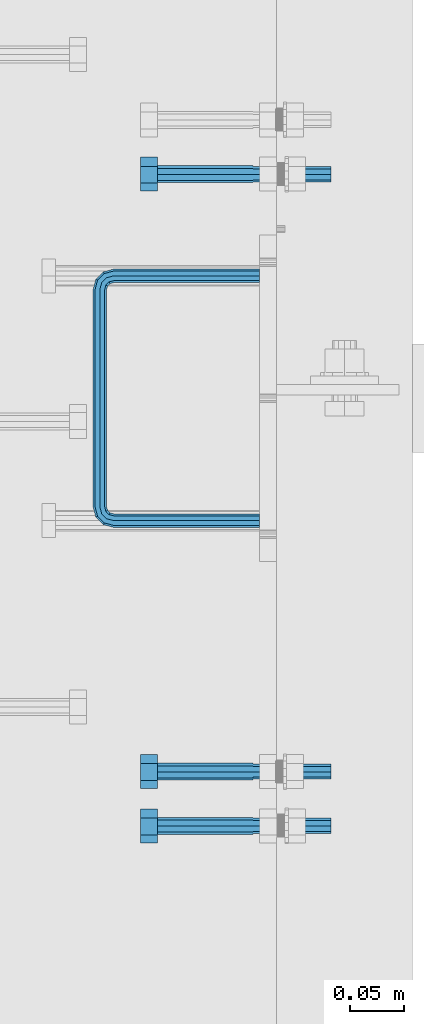
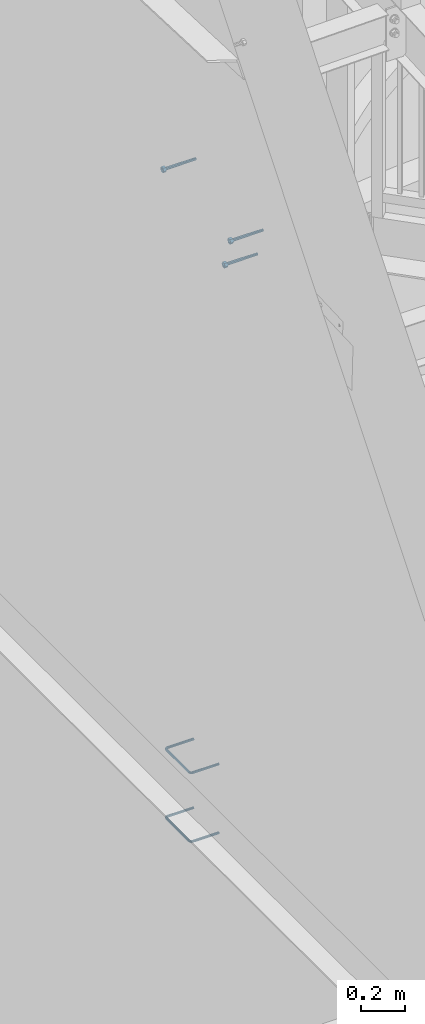
# One storey, part 470 of 975: 5 beams.
"""IFC2X3 building model written with IfcOpenShell, lengths in millimetres."""

from ifc_helpers import new_model, si_unit, frame, origin_with_axes, place, context, subcontext, project, spatial, faceted_brep, material, type_object, element, save


model = new_model("IFC2X3")

# Units and contexts
model_context = context("Model", 3, precision=1e-05, world=origin_with_axes())
body_context = subcontext(model_context, "Body", "Model", "MODEL_VIEW")
ifc_project = project(units=[si_unit("LENGTHUNIT", "METRE", prefix="MILLI"), si_unit("AREAUNIT", "SQUARE_METRE"), si_unit("VOLUMEUNIT", "CUBIC_METRE"), si_unit("MASSUNIT", "GRAM", prefix="KILO"), si_unit("TIMEUNIT", "SECOND"), si_unit("PLANEANGLEUNIT", "RADIAN"), si_unit("SOLIDANGLEUNIT", "STERADIAN"), si_unit("THERMODYNAMICTEMPERATUREUNIT", "DEGREE_CELSIUS"), si_unit("LUMINOUSINTENSITYUNIT", "LUMEN")], contexts=[model_context])

# Site, building, storey
site_placement = place(None, origin_with_axes())
site = spatial("IfcSite", under=ifc_project, at=site_placement, CompositionType="ELEMENT")
building_placement = place(site_placement, origin_with_axes())
building = spatial("IfcBuilding", under=site, at=building_placement, Name="Undefined", CompositionType="ELEMENT")
storey_placement = place(building_placement, origin_with_axes())
storey = spatial("IfcBuildingStorey", under=building, at=storey_placement, Name="Undefined", CompositionType="ELEMENT", Elevation=0.0)

# Beams
ifc_material_1 = material(Name="STEEL/F1554-36")
beam_type_1 = type_object("IfcBeamType", PredefinedType="NOTDEFINED")
beam_1_placement = place(storey_placement, frame((29937.0748667448, 2263.56850308792, 6917.15674661512), z_axis=(-7.0905516622588e-09, -0.0430877640020049, 0.999071291046494), x_axis=(-0.999999999999998, 6.90000001668524e-08, 0.0)))
element("IfcBeam", 1, at=beam_1_placement, inside=storey, type_object=beam_type_1, material=ifc_material_1, Name="HEADED_ANCHOR_BOLT", context=body_context, shape_type="Brep", body=[
    faceted_brep([(88.900000064019, -7.94000009583215, -13.7499999799147), (88.9000000184824, 7.94000001861696, -13.7499999799138), (104.775000018315, 7.94000006417082, -13.7499999302891), (104.775000063852, -7.9400000502792, -13.74999993029), (88.9000000438027, -15.880000153059, 2.00925569515675e-08), (104.775000043643, -15.8800001075042, 6.9716406869702e-08), (88.8999999780608, -7.94000009583488, 13.7500000200998), (104.774999977893, -7.94000005028101, 13.7500000697237), (88.8999999325279, 7.94000001861514, 13.7500000201007), (104.774999932361, 7.940000064169, 13.7500000697246), (88.8999999527368, 15.8800000758411, 2.00943759409711e-08), (104.774999952569, 15.8800001213949, 6.97191353538074e-08), (88.9000000119959, 3.78780480527439, -7.86545778426807), (88.8999999957159, 6.82538844544797, -5.4430656647246), (88.8999999799416, 8.51112018845743, -1.94260763148395), (88.8999999677944, 8.51112018845652, 1.94260767167179), (88.8999999616899, 6.82538844544615, 5.44306570491244), (88.8999999628249, 3.78780480527257, 7.86545782445592), (88.8999999709849, -3.86089595849626e-08, 8.72999956233434), (88.8999999845473, -3.7878048824914, 7.8654578244541), (88.9000000008309, -6.82538852266407, 5.44306570491153), (88.9000000166052, -8.51112026567444, 1.94260767166998), (88.9000000287488, -8.51112026567353, -1.94260763148577), (88.9000000348606, -6.82538852266407, -5.44306566472642), (88.9000000337182, -3.78780488248958, -7.86545778426898), (88.9000000255583, -3.86080500902608e-08, -8.72999952214832), (104.775000025395, 6.94581103743985e-09, -8.72999947252447), (104.775000011829, 3.78780485082825, -7.86545773464422), (104.774999995549, 6.82538849100092, -5.44306561510075), (104.774999979774, 8.51112023401038, -1.9426075818601), (104.774999967627, 8.51112023401038, 1.94260772129564), (104.774999961523, 6.82538849100092, 5.44306575453629), (104.774999962658, 3.78780485082643, 7.86545787407977), (104.774999970818, 6.94399204803631e-09, 8.7299996119591), (104.77499998438, -3.78780483693754, 7.86545787407886), (104.775000000664, -6.82538847711112, 5.44306575453538), (104.775000016438, -8.51112022012057, 1.94260772129473), (104.775000028581, -8.51112022012057, -1.94260758186101), (104.775000034693, -6.82538847711021, -5.44306561510166), (104.775000033551, -3.78780483693663, -7.86545773464422), (-2.99107341561466e-07, -5.61266007567065, -5.61266007566792), (-1.09139364212751e-11, 1.81898940354586e-12, -7.9375), (104.774999998099, 1.2732925824821e-11, -7.93750000004547), (104.774999998092, -5.612660075657, -5.6126600757143), (2.99089151667431e-07, 5.61266007567428, -5.61266007566792), (104.774999998102, 5.61266007568156, -5.61266007571339), (4.22980519942939e-07, 7.93750000001091, 0.0), (104.77499999811, 7.93750000001364, -4.36557456851006e-11), (2.99089151667431e-07, 5.61266007567428, 5.61266007566792), (104.774999998102, 5.61266007568065, 5.61266007562517), (-1.09139364212751e-11, 1.81898940354586e-12, 7.9375), (104.774999998095, 1.18234311230481e-11, 7.93749999995816), (-2.99107341561466e-07, -5.61266007567065, 5.61266007566792), (104.774999998088, -5.61266007565791, 5.61266007562426), (-4.22995071858168e-07, -7.93750000000728, 0.0), (104.774999998088, -7.93749999999, -4.45652403868735e-11), (0.00624994074678398, 5.05157085007704, 5.05157081110701), (0.00624993484598235, 5.2777977543883e-09, 7.14399996631164), (0.00624996711121639, -5.05157083952145, 5.05157081110519), (0.00625001864682417, -7.14399999472516, -3.36940502165817e-08), (0.00625005926485755, -5.05157083952145, -5.05157087849329), (0.00625006516929716, 5.27870724909008e-09, -7.1440000336961), (0.00625003290042514, 5.05157085007795, -5.05157087849238), (0.00624998136845534, 7.14400000528167, -3.36922312271781e-08), (-73.0249999592124, 5.05157065939329, -5.0515715445581), (-73.0249999269472, -1.85405951924622e-07, -7.14400069976364), (-73.0249999328516, -5.0515710302052, -5.05157154455992), (-73.0249999734697, -7.14400018541073, -6.9975976657588e-07), (-73.0250000250016, -5.05157103020611, 5.05157014504039), (-73.0250000572705, -1.85406861419324e-07, 7.1439993002441), (-73.0250000513661, 5.05157065939238, 5.05157014503948), (-73.025000010748, 7.14399981459792, -6.99758857081179e-07)], [[[0, 1, 2, 3]], [[4, 0, 3, 5]], [[6, 4, 5, 7]], [[8, 6, 7, 9]], [[10, 8, 9, 11]], [[1, 0, 4, 6, 8, 10], [12, 13, 14, 15, 16, 17, 18, 19, 20, 21, 22, 23, 24, 25]], [[12, 25, 26, 27]], [[13, 12, 27, 28]], [[14, 13, 28, 29]], [[15, 14, 29, 30]], [[16, 15, 30, 31]], [[17, 16, 31, 32]], [[18, 17, 32, 33]], [[19, 18, 33, 34]], [[20, 19, 34, 35]], [[21, 20, 35, 36]], [[22, 21, 36, 37]], [[23, 22, 37, 38]], [[24, 23, 38, 39]], [[25, 24, 39, 26]], [[7, 5, 3, 2, 11, 9], [38, 37, 36, 35, 34, 33, 32, 31, 30, 29, 28, 27, 26, 39]], [[1, 10, 11, 2]], [[40, 41, 42, 43]], [[41, 44, 45, 42]], [[44, 46, 47, 45]], [[46, 48, 49, 47]], [[48, 50, 51, 49]], [[50, 52, 53, 51]], [[52, 54, 55, 53]], [[42, 45, 47, 49, 51, 53, 55, 43]], [[54, 40, 43, 55]], [[52, 50, 48, 46, 44, 41, 40, 54], [56, 57, 58, 59, 60, 61, 62, 63]], [[64, 65, 66, 67, 68, 69, 70, 71]], [[70, 69, 57, 56]], [[71, 70, 56, 63]], [[64, 71, 63, 62]], [[65, 64, 62, 61]], [[66, 65, 61, 60]], [[67, 66, 60, 59]], [[68, 67, 59, 58]], [[69, 68, 58, 57]]]),
])
beam_2_placement = place(storey_placement, frame((29937.0747319713, 2821.85899310216, 7106.48806983563), z_axis=(3.96407267544419e-09, 0.0430877640020053, -0.999071291046494), x_axis=(-0.999999999999998, 6.90000001668524e-08, 0.0)))
element("IfcBeam", 2, at=beam_2_placement, inside=storey, type_object=beam_type_1, material=ifc_material_1, Name="HEADED_ANCHOR_BOLT", context=body_context, shape_type="Brep", body=[
    faceted_brep([(88.9000000184824, 7.94000001861696, -13.7499999799138), (88.8999999527368, 15.8800000758411, 2.00943759409711e-08), (104.774999952569, 15.8800001213949, 6.97191353538074e-08), (104.775000018315, 7.94000006417082, -13.7499999302891), (88.900000064019, -7.94000009583215, -13.7499999799147), (104.775000063852, -7.9400000502792, -13.74999993029), (88.9000000438027, -15.880000153059, 2.00925569515675e-08), (104.775000043643, -15.8800001075042, 6.9716406869702e-08), (88.8999999780608, -7.94000009583488, 13.7500000200998), (104.774999977893, -7.94000005028101, 13.7500000697237), (88.8999999325279, 7.94000001861514, 13.7500000201007), (104.774999932361, 7.940000064169, 13.7500000697246), (88.9000000119959, 3.78780480527439, -7.86545778426807), (88.8999999957159, 6.82538844544797, -5.4430656647246), (88.8999999799416, 8.51112018845743, -1.94260763148395), (88.8999999677944, 8.51112018845652, 1.94260767167179), (88.8999999616899, 6.82538844544615, 5.44306570491244), (88.8999999628249, 3.78780480527257, 7.86545782445592), (88.8999999709849, -3.86089595849626e-08, 8.72999956233434), (88.8999999845473, -3.7878048824914, 7.8654578244541), (88.9000000008309, -6.82538852266407, 5.44306570491153), (88.9000000166052, -8.51112026567444, 1.94260767166998), (88.9000000287488, -8.51112026567353, -1.94260763148577), (88.9000000348606, -6.82538852266407, -5.44306566472642), (88.9000000337182, -3.78780488248958, -7.86545778426898), (88.9000000255583, -3.86080500902608e-08, -8.72999952214832), (104.775000025395, 6.94581103743985e-09, -8.72999947252447), (104.775000011829, 3.78780485082825, -7.86545773464422), (104.774999995549, 6.82538849100092, -5.44306561510075), (104.774999979774, 8.51112023401038, -1.9426075818601), (104.774999967627, 8.51112023401038, 1.94260772129564), (104.774999961523, 6.82538849100092, 5.44306575453629), (104.774999962658, 3.78780485082643, 7.86545787407977), (104.774999970818, 6.94399204803631e-09, 8.7299996119591), (104.77499998438, -3.78780483693754, 7.86545787407886), (104.775000000664, -6.82538847711112, 5.44306575453538), (104.775000016438, -8.51112022012057, 1.94260772129473), (104.775000028581, -8.51112022012057, -1.94260758186101), (104.775000034693, -6.82538847711021, -5.44306561510166), (104.775000033551, -3.78780483693663, -7.86545773464422), (-2.99107341561466e-07, -5.61266007567065, 5.61266007566792), (-4.22995071858168e-07, -7.93750000000728, 0.0), (104.774999998088, -7.93749999999, -4.45652403868735e-11), (104.774999998088, -5.61266007565791, 5.61266007562426), (-1.09139364212751e-11, 1.81898940354586e-12, 7.9375), (104.774999998095, 1.18234311230481e-11, 7.93749999995816), (2.99089151667431e-07, 5.61266007567428, 5.61266007566792), (104.774999998102, 5.61266007568065, 5.61266007562517), (4.22980519942939e-07, 7.93750000001091, 0.0), (104.77499999811, 7.93750000001364, -4.36557456851006e-11), (2.99089151667431e-07, 5.61266007567428, -5.61266007566792), (104.774999998102, 5.61266007568156, -5.61266007571339), (-1.09139364212751e-11, 1.81898940354586e-12, -7.9375), (104.774999998099, 1.2732925824821e-11, -7.93750000004547), (-73.0249999592124, 5.05157065939329, -5.0515715445581), (-73.0249999269472, -1.85405951924622e-07, -7.14400069976364), (-73.0249999328516, -5.0515710302052, -5.05157154455992), (-73.0249999734697, -7.14400018541073, -6.9975976657588e-07), (-73.0250000250016, -5.05157103020611, 5.05157014504039), (-73.0250000572705, -1.85406861419324e-07, 7.1439993002441), (-73.0250000513661, 5.05157065939238, 5.05157014503948), (-73.025000010748, 7.14399981459792, -6.99758857081179e-07), (0.00625003290042514, 5.05157085007795, -5.05157087849238), (0.00625006516929716, 5.27870724909008e-09, -7.1440000336961), (0.00625005926485755, -5.05157083952145, -5.05157087849329), (0.00625001864682417, -7.14399999472516, -3.36940502165817e-08), (0.00624996711121639, -5.05157083952145, 5.05157081110519), (0.00624993484598235, 5.2777977543883e-09, 7.14399996631164), (0.00624994074678398, 5.05157085007704, 5.05157081110701), (0.00624998136845534, 7.14400000528167, -3.36922312271781e-08), (-2.99107341561466e-07, -5.61266007567065, -5.61266007566792), (104.774999998092, -5.612660075657, -5.6126600757143)], [[[0, 1, 2, 3]], [[4, 0, 3, 5]], [[6, 4, 5, 7]], [[8, 6, 7, 9]], [[10, 8, 9, 11]], [[0, 4, 6, 8, 10, 1], [12, 13, 14, 15, 16, 17, 18, 19, 20, 21, 22, 23, 24, 25]], [[12, 25, 26, 27]], [[13, 12, 27, 28]], [[14, 13, 28, 29]], [[15, 14, 29, 30]], [[16, 15, 30, 31]], [[17, 16, 31, 32]], [[18, 17, 32, 33]], [[19, 18, 33, 34]], [[20, 19, 34, 35]], [[21, 20, 35, 36]], [[22, 21, 36, 37]], [[23, 22, 37, 38]], [[24, 23, 38, 39]], [[25, 24, 39, 26]], [[9, 7, 5, 3, 2, 11], [38, 37, 36, 35, 34, 33, 32, 31, 30, 29, 28, 27, 26, 39]], [[1, 10, 11, 2]], [[40, 41, 42, 43]], [[44, 40, 43, 45]], [[46, 44, 45, 47]], [[48, 46, 47, 49]], [[50, 48, 49, 51]], [[52, 50, 51, 53]], [[54, 55, 56, 57, 58, 59, 60, 61]], [[55, 54, 62, 63]], [[56, 55, 63, 64]], [[57, 56, 64, 65]], [[58, 57, 65, 66]], [[59, 58, 66, 67]], [[60, 59, 67, 68]], [[61, 60, 68, 69]], [[54, 61, 69, 62]], [[40, 44, 46, 48, 50, 52, 70, 41], [68, 67, 66, 65, 64, 63, 62, 69]], [[41, 70, 71, 42]], [[53, 51, 49, 47, 45, 43, 42, 71]], [[70, 52, 53, 71]]]),
])
beam_3_placement = place(storey_placement, frame((29937.0747837873, 2212.82505231366, 7080.22176473988), z_axis=(-7.0905516622588e-09, -0.0430877640020049, 0.999071291046494), x_axis=(-0.999999999999998, 6.90000001668524e-08, 0.0)))
element("IfcBeam", 3, at=beam_3_placement, inside=storey, type_object=beam_type_1, material=ifc_material_1, Name="HEADED_ANCHOR_BOLT", context=body_context, shape_type="Brep", body=[
    faceted_brep([(88.9000000184824, 7.94000001861696, -13.7499999799138), (88.8999999527368, 15.8800000758411, 2.00943759409711e-08), (104.774999952569, 15.8800001213949, 6.97191353538074e-08), (104.775000018315, 7.94000006417082, -13.7499999302891), (88.900000064019, -7.94000009583215, -13.7499999799147), (104.775000063852, -7.9400000502792, -13.74999993029), (88.9000000438027, -15.880000153059, 2.00925569515675e-08), (104.775000043643, -15.8800001075042, 6.9716406869702e-08), (88.8999999780608, -7.94000009583488, 13.7500000200998), (104.774999977893, -7.94000005028101, 13.7500000697237), (88.8999999325279, 7.94000001861514, 13.7500000201007), (104.774999932361, 7.940000064169, 13.7500000697246), (88.9000000119959, 3.78780480527439, -7.86545778426807), (88.8999999957159, 6.82538844544797, -5.4430656647246), (88.8999999799416, 8.51112018845743, -1.94260763148395), (88.8999999677944, 8.51112018845652, 1.94260767167179), (88.8999999616899, 6.82538844544615, 5.44306570491244), (88.8999999628249, 3.78780480527257, 7.86545782445592), (88.8999999709849, -3.86089595849626e-08, 8.72999956233434), (88.8999999845473, -3.7878048824914, 7.8654578244541), (88.9000000008309, -6.82538852266407, 5.44306570491153), (88.9000000166052, -8.51112026567444, 1.94260767166998), (88.9000000287488, -8.51112026567353, -1.94260763148577), (88.9000000348606, -6.82538852266407, -5.44306566472642), (88.9000000337182, -3.78780488248958, -7.86545778426898), (88.9000000255583, -3.86080500902608e-08, -8.72999952214832), (104.775000025395, 6.94581103743985e-09, -8.72999947252447), (104.775000011829, 3.78780485082825, -7.86545773464422), (104.774999995549, 6.82538849100092, -5.44306561510075), (104.774999979774, 8.51112023401038, -1.9426075818601), (104.774999967627, 8.51112023401038, 1.94260772129564), (104.774999961523, 6.82538849100092, 5.44306575453629), (104.774999962658, 3.78780485082643, 7.86545787407977), (104.774999970818, 6.94399204803631e-09, 8.7299996119591), (104.77499998438, -3.78780483693754, 7.86545787407886), (104.775000000664, -6.82538847711112, 5.44306575453538), (104.775000016438, -8.51112022012057, 1.94260772129473), (104.775000028581, -8.51112022012057, -1.94260758186101), (104.775000034693, -6.82538847711021, -5.44306561510166), (104.775000033551, -3.78780483693663, -7.86545773464422), (-2.99107341561466e-07, -5.61266007567065, 5.61266007566792), (-4.22995071858168e-07, -7.93750000000728, 0.0), (104.774999998088, -7.93749999999, -4.45652403868735e-11), (104.774999998088, -5.61266007565791, 5.61266007562426), (-1.09139364212751e-11, 1.81898940354586e-12, 7.9375), (104.774999998095, 1.18234311230481e-11, 7.93749999995816), (2.99089151667431e-07, 5.61266007567428, 5.61266007566792), (104.774999998102, 5.61266007568065, 5.61266007562517), (4.22980519942939e-07, 7.93750000001091, 0.0), (104.77499999811, 7.93750000001364, -4.36557456851006e-11), (2.99089151667431e-07, 5.61266007567428, -5.61266007566792), (104.774999998102, 5.61266007568156, -5.61266007571339), (-1.09139364212751e-11, 1.81898940354586e-12, -7.9375), (104.774999998099, 1.2732925824821e-11, -7.93750000004547), (-73.0249999592124, 5.05157065939329, -5.0515715445581), (-73.0249999269472, -1.85405951924622e-07, -7.14400069976364), (-73.0249999328516, -5.0515710302052, -5.05157154455992), (-73.0249999734697, -7.14400018541073, -6.9975976657588e-07), (-73.0250000250016, -5.05157103020611, 5.05157014504039), (-73.0250000572705, -1.85406861419324e-07, 7.1439993002441), (-73.0250000513661, 5.05157065939238, 5.05157014503948), (-73.025000010748, 7.14399981459792, -6.99758857081179e-07), (0.00625003290042514, 5.05157085007795, -5.05157087849238), (0.00625006516929716, 5.27870724909008e-09, -7.1440000336961), (0.00625005926485755, -5.05157083952145, -5.05157087849329), (0.00625001864682417, -7.14399999472516, -3.36940502165817e-08), (0.00624996711121639, -5.05157083952145, 5.05157081110519), (0.00624993484598235, 5.2777977543883e-09, 7.14399996631164), (0.00624994074678398, 5.05157085007704, 5.05157081110701), (0.00624998136845534, 7.14400000528167, -3.36922312271781e-08), (-2.99107341561466e-07, -5.61266007567065, -5.61266007566792), (104.774999998092, -5.612660075657, -5.6126600757143)], [[[0, 1, 2, 3]], [[4, 0, 3, 5]], [[6, 4, 5, 7]], [[8, 6, 7, 9]], [[10, 8, 9, 11]], [[0, 4, 6, 8, 10, 1], [12, 13, 14, 15, 16, 17, 18, 19, 20, 21, 22, 23, 24, 25]], [[12, 25, 26, 27]], [[13, 12, 27, 28]], [[14, 13, 28, 29]], [[15, 14, 29, 30]], [[16, 15, 30, 31]], [[17, 16, 31, 32]], [[18, 17, 32, 33]], [[19, 18, 33, 34]], [[20, 19, 34, 35]], [[21, 20, 35, 36]], [[22, 21, 36, 37]], [[23, 22, 37, 38]], [[24, 23, 38, 39]], [[25, 24, 39, 26]], [[9, 7, 5, 3, 2, 11], [38, 37, 36, 35, 34, 33, 32, 31, 30, 29, 28, 27, 26, 39]], [[1, 10, 11, 2]], [[40, 41, 42, 43]], [[44, 40, 43, 45]], [[46, 44, 45, 47]], [[48, 46, 47, 49]], [[50, 48, 49, 51]], [[52, 50, 51, 53]], [[54, 55, 56, 57, 58, 59, 60, 61]], [[55, 54, 62, 63]], [[56, 55, 63, 64]], [[57, 56, 64, 65]], [[58, 57, 65, 66]], [[59, 58, 66, 67]], [[60, 59, 67, 68]], [[61, 60, 68, 69]], [[54, 61, 69, 62]], [[40, 44, 46, 48, 50, 52, 70, 41], [68, 67, 66, 65, 64, 63, 62, 69]], [[41, 70, 71, 42]], [[53, 51, 49, 47, 45, 43, 42, 71]], [[70, 52, 53, 71]]]),
])
ifc_material_2 = material(Name="STEEL/A706")
beam_type_2 = type_object("IfcBeamType", Name="#4 TIE", PredefinedType="NOTDEFINED")
beam_4_placement = place(storey_placement, frame((29943.425, 2498.12968394824, 3971.925), z_axis=(0.0, 1.0, 0.0), x_axis=(-0.999999999999998, 6.90000001668524e-08, 0.0)))
element("IfcBeam", 4, at=beam_4_placement, inside=storey, type_object=beam_type_2, material=ifc_material_2, Name="TIE ROD", ObjectType="#4 TIE", context=body_context, shape_type="Brep", body=[
    faceted_brep([(0.0, -6.34999999998763, -3.63797880709171e-12), (0.0, -4.49012806052269, -4.49012806054634), (136.525006144455, -4.49012806053452, -4.49012811661669), (136.525006146271, -6.35000000000036, -5.60821717954241e-08), (0.0, 7.27595761418343e-12, -6.35000000000764), (136.525006143703, 0.0, -6.35000005608254), (0.0, 4.49012806053724, -4.49012806053906), (136.525006144455, 4.49012806053452, -4.49012811661669), (0.0, 6.34999999999491, 5.45696821063757e-12), (136.525006146271, 6.35000000000036, -5.60821717954241e-08), (0.0, 4.49012806052633, 4.49012806054634), (136.525006148087, 4.49012806053452, 4.49012800445234), (0.0, 0.0, 6.35000000000764), (136.525006148839, 0.0, 6.34999994391819), (0.0, -4.49012806053361, 4.49012806053543), (136.525006148087, -4.49012806053452, 4.49012800445234), (146.050006113442, 0.0, -3.79778399058796), (145.120070138105, -4.49012806053452, -2.1870876464609), (142.875006094308, -6.35000000000036, 1.70147731239558), (140.62994205051, -4.49012806053452, 5.59004227125297), (139.700006075173, 0.0, 7.20073861538003), (140.62994205051, 4.49012806053452, 5.59004227125297), (142.875006094308, 6.35000000000036, 1.70147731239558), (145.120070138105, 4.49012806053452, -2.1870876464609), (151.412093644245, 4.49012806053452, 4.10493592790226), (153.022789998455, 0.0, 3.1749999700296), (147.523528661045, 6.35000000000036, 6.34999992953635), (143.634963677846, 4.49012806053452, 8.59506393117135), (142.024267323636, 0.0, 9.5249998890431), (143.634963677846, -4.49012806053452, 8.59506393117135), (147.523528661045, -6.35000000000036, 6.34999992953635), (151.412093644245, -4.49012806053452, 4.10493592790226), (153.715134021207, 4.49012806053452, 12.6999999465306), (155.575005960673, 0.0, 12.6999999674508), (149.225005960672, 6.35000000000036, 12.6999998960273), (144.734877900137, 4.49012806053452, 12.699999845524), (142.875005960672, 0.0, 12.6999998246056), (144.734877900137, -4.49012806053452, 12.699999845524), (149.225005960671, -6.35000000000036, 12.6999998960273), (153.715134021207, -4.49012806053452, 12.6999999465306), (153.71513173569, -4.49012806053452, 215.900003176369), (149.225003675155, -6.35000000000036, 215.900003125867), (155.575003675155, 0.0, 215.900003197289), (153.71513173569, 4.49012806053452, 215.900003176369), (149.225003675155, 6.35000000000036, 215.900003125867), (144.734875614621, 4.49012806053452, 215.900003075363), (142.875003675155, 0.0, 215.900003054444), (144.734875614621, -4.49012806053452, 215.900003075363), (153.022787648382, 0.0, 225.425002877988), (151.412091300475, -4.49012806053452, 224.495066909199), (147.523526332491, -6.35000000000036, 222.25000288121), (143.634961364508, -4.49012806053452, 220.004938853222), (142.024265016601, 0.0, 219.075002884432), (143.634961364508, 4.49012806053452, 220.004938853222), (147.523526332491, 6.35000000000036, 222.25000288121), (151.412091300475, 4.49012806053452, 224.495066909199), (145.120067985683, 4.49012806053452, 230.787090305822), (146.05000397542, 0.0, 232.397786641635), (142.875003907121, 6.35000000000036, 226.898525367037), (140.629939828559, 4.49012806053452, 223.00996042825), (139.700003838822, 0.0, 221.399264092438), (140.629939828559, -4.49012806053452, 223.00996042825), (142.875003907121, -6.35000000000036, 226.898525367037), (145.120067985683, -4.49012806053452, 230.787090305822), (136.525004282814, 4.49012806053452, 233.090130852819), (136.525004327922, 0.0, 234.950002792285), (136.525004173912, 6.35000000000036, 228.600002792285), (136.52500406501, 4.49012806053452, 224.10987473175), (136.525004019901, 0.0, 222.250002792285), (136.52500406501, -4.49012806053452, 224.10987473175), (136.525004173912, -6.35000000000036, 228.600002792286), (136.525004282814, -4.49012806053452, 233.090130852819), (3.32236731992452e-06, -4.49012806053452, 233.090134164055), (3.21346533382894e-06, -6.35000000000036, 228.60000610352), (3.36747552864836e-06, 0.0, 234.95000610352), (3.32236731992452e-06, 4.49012806053452, 233.090134164055), (3.21346533382894e-06, 6.35000000000036, 228.60000610352), (3.104562892986e-06, 4.49012806053452, 224.109878042986), (3.05945422951481e-06, 0.0, 222.25000610352), (3.104562892986e-06, -4.49012806053452, 224.109878042986)], [[[0, 1, 2, 3]], [[1, 4, 5, 2]], [[4, 6, 7, 5]], [[6, 8, 9, 7]], [[8, 10, 11, 9]], [[10, 12, 13, 11]], [[12, 14, 15, 13]], [[14, 0, 3, 15]], [[14, 12, 10, 8, 6, 4, 1, 0]], [[2, 5, 16, 17]], [[3, 2, 17, 18]], [[15, 3, 18, 19]], [[13, 15, 19, 20]], [[11, 13, 20, 21]], [[9, 11, 21, 22]], [[7, 9, 22, 23]], [[5, 7, 23, 16]], [[23, 24, 25, 16]], [[22, 26, 24, 23]], [[21, 27, 26, 22]], [[20, 28, 27, 21]], [[19, 29, 28, 20]], [[18, 30, 29, 19]], [[17, 31, 30, 18]], [[16, 25, 31, 17]], [[24, 32, 33, 25]], [[26, 34, 32, 24]], [[27, 35, 34, 26]], [[28, 36, 35, 27]], [[29, 37, 36, 28]], [[30, 38, 37, 29]], [[31, 39, 38, 30]], [[25, 33, 39, 31]], [[38, 39, 40, 41]], [[39, 33, 42, 40]], [[33, 32, 43, 42]], [[32, 34, 44, 43]], [[34, 35, 45, 44]], [[35, 36, 46, 45]], [[36, 37, 47, 46]], [[37, 38, 41, 47]], [[40, 42, 48, 49]], [[41, 40, 49, 50]], [[47, 41, 50, 51]], [[46, 47, 51, 52]], [[45, 46, 52, 53]], [[44, 45, 53, 54]], [[43, 44, 54, 55]], [[42, 43, 55, 48]], [[55, 56, 57, 48]], [[54, 58, 56, 55]], [[53, 59, 58, 54]], [[52, 60, 59, 53]], [[51, 61, 60, 52]], [[50, 62, 61, 51]], [[49, 63, 62, 50]], [[48, 57, 63, 49]], [[56, 64, 65, 57]], [[58, 66, 64, 56]], [[59, 67, 66, 58]], [[60, 68, 67, 59]], [[61, 69, 68, 60]], [[62, 70, 69, 61]], [[63, 71, 70, 62]], [[57, 65, 71, 63]], [[70, 71, 72, 73]], [[71, 65, 74, 72]], [[65, 64, 75, 74]], [[64, 66, 76, 75]], [[66, 67, 77, 76]], [[67, 68, 78, 77]], [[68, 69, 79, 78]], [[69, 70, 73, 79]], [[74, 75, 76, 77, 78, 79, 73, 72]]]),
])
beam_5_placement = place(storey_placement, frame((29943.425, 2498.12968394824, 3590.92498779297), z_axis=(0.0, 1.0, 0.0), x_axis=(-0.999999999999998, 6.90000001668524e-08, 0.0)))
element("IfcBeam", 5, at=beam_5_placement, inside=storey, type_object=beam_type_2, material=ifc_material_2, Name="TIE ROD", ObjectType="#4 TIE", context=body_context, shape_type="Brep", body=[
    faceted_brep([(0.0, -6.34999999998763, -3.63797880709171e-12), (0.0, -4.49012806052269, -4.49012806054634), (136.525006144455, -4.49012806053452, -4.49012811661669), (136.525006146271, -6.35000000000036, -5.60821717954241e-08), (0.0, 7.27595761418343e-12, -6.35000000000764), (136.525006143703, 0.0, -6.35000005608254), (0.0, 4.49012806053724, -4.49012806053906), (136.525006144455, 4.49012806053452, -4.49012811661669), (0.0, 6.34999999999491, 5.45696821063757e-12), (136.525006146271, 6.35000000000036, -5.60821717954241e-08), (0.0, 4.49012806052633, 4.49012806054634), (136.525006148087, 4.49012806053452, 4.49012800445234), (0.0, 0.0, 6.35000000000764), (136.525006148839, 0.0, 6.34999994391819), (0.0, -4.49012806053361, 4.49012806053543), (136.525006148087, -4.49012806053452, 4.49012800445234), (146.050006113442, 0.0, -3.79778399058796), (145.120070138105, -4.49012806053452, -2.1870876464609), (142.875006094308, -6.35000000000036, 1.70147731239558), (140.62994205051, -4.49012806053452, 5.59004227125297), (139.700006075173, 0.0, 7.20073861538003), (140.62994205051, 4.49012806053452, 5.59004227125297), (142.875006094308, 6.35000000000036, 1.70147731239558), (145.120070138105, 4.49012806053452, -2.1870876464609), (151.412093644245, 4.49012806053452, 4.10493592790226), (153.022789998455, 0.0, 3.1749999700296), (147.523528661045, 6.35000000000036, 6.34999992953635), (143.634963677846, 4.49012806053452, 8.59506393117135), (142.024267323636, 0.0, 9.5249998890431), (143.634963677846, -4.49012806053452, 8.59506393117135), (147.523528661045, -6.35000000000036, 6.34999992953635), (151.412093644245, -4.49012806053452, 4.10493592790226), (153.715134021207, 4.49012806053452, 12.6999999465306), (155.575005960673, 0.0, 12.6999999674508), (149.225005960672, 6.35000000000036, 12.6999998960273), (144.734877900137, 4.49012806053452, 12.699999845524), (142.875005960672, 0.0, 12.6999998246056), (144.734877900137, -4.49012806053452, 12.699999845524), (149.225005960671, -6.35000000000036, 12.6999998960273), (153.715134021207, -4.49012806053452, 12.6999999465306), (153.71513173569, -4.49012806053452, 215.900003176369), (149.225003675155, -6.35000000000036, 215.900003125867), (155.575003675155, 0.0, 215.900003197289), (153.71513173569, 4.49012806053452, 215.900003176369), (149.225003675155, 6.35000000000036, 215.900003125867), (144.734875614621, 4.49012806053452, 215.900003075363), (142.875003675155, 0.0, 215.900003054444), (144.734875614621, -4.49012806053452, 215.900003075363), (153.022787648382, 0.0, 225.425002877988), (151.412091300475, -4.49012806053452, 224.495066909199), (147.523526332491, -6.35000000000036, 222.25000288121), (143.634961364508, -4.49012806053452, 220.004938853222), (142.024265016601, 0.0, 219.075002884432), (143.634961364508, 4.49012806053452, 220.004938853222), (147.523526332491, 6.35000000000036, 222.25000288121), (151.412091300475, 4.49012806053452, 224.495066909199), (145.120067985683, 4.49012806053452, 230.787090305822), (146.05000397542, 0.0, 232.397786641635), (142.875003907121, 6.35000000000036, 226.898525367037), (140.629939828559, 4.49012806053452, 223.00996042825), (139.700003838822, 0.0, 221.399264092438), (140.629939828559, -4.49012806053452, 223.00996042825), (142.875003907121, -6.35000000000036, 226.898525367037), (145.120067985683, -4.49012806053452, 230.787090305822), (136.525004282814, 4.49012806053452, 233.090130852819), (136.525004327922, 0.0, 234.950002792285), (136.525004173912, 6.35000000000036, 228.600002792285), (136.52500406501, 4.49012806053452, 224.10987473175), (136.525004019901, 0.0, 222.250002792285), (136.52500406501, -4.49012806053452, 224.10987473175), (136.525004173912, -6.35000000000036, 228.600002792286), (136.525004282814, -4.49012806053452, 233.090130852819), (3.32236731992452e-06, -4.49012806053452, 233.090134164055), (3.21346533382894e-06, -6.35000000000036, 228.60000610352), (3.36747552864836e-06, 0.0, 234.95000610352), (3.32236731992452e-06, 4.49012806053452, 233.090134164055), (3.21346533382894e-06, 6.35000000000036, 228.60000610352), (3.104562892986e-06, 4.49012806053452, 224.109878042986), (3.05945422951481e-06, 0.0, 222.25000610352), (3.104562892986e-06, -4.49012806053452, 224.109878042986)], [[[0, 1, 2, 3]], [[1, 4, 5, 2]], [[4, 6, 7, 5]], [[6, 8, 9, 7]], [[8, 10, 11, 9]], [[10, 12, 13, 11]], [[12, 14, 15, 13]], [[14, 0, 3, 15]], [[14, 12, 10, 8, 6, 4, 1, 0]], [[2, 5, 16, 17]], [[3, 2, 17, 18]], [[15, 3, 18, 19]], [[13, 15, 19, 20]], [[11, 13, 20, 21]], [[9, 11, 21, 22]], [[7, 9, 22, 23]], [[5, 7, 23, 16]], [[23, 24, 25, 16]], [[22, 26, 24, 23]], [[21, 27, 26, 22]], [[20, 28, 27, 21]], [[19, 29, 28, 20]], [[18, 30, 29, 19]], [[17, 31, 30, 18]], [[16, 25, 31, 17]], [[24, 32, 33, 25]], [[26, 34, 32, 24]], [[27, 35, 34, 26]], [[28, 36, 35, 27]], [[29, 37, 36, 28]], [[30, 38, 37, 29]], [[31, 39, 38, 30]], [[25, 33, 39, 31]], [[38, 39, 40, 41]], [[39, 33, 42, 40]], [[33, 32, 43, 42]], [[32, 34, 44, 43]], [[34, 35, 45, 44]], [[35, 36, 46, 45]], [[36, 37, 47, 46]], [[37, 38, 41, 47]], [[40, 42, 48, 49]], [[41, 40, 49, 50]], [[47, 41, 50, 51]], [[46, 47, 51, 52]], [[45, 46, 52, 53]], [[44, 45, 53, 54]], [[43, 44, 54, 55]], [[42, 43, 55, 48]], [[55, 56, 57, 48]], [[54, 58, 56, 55]], [[53, 59, 58, 54]], [[52, 60, 59, 53]], [[51, 61, 60, 52]], [[50, 62, 61, 51]], [[49, 63, 62, 50]], [[48, 57, 63, 49]], [[56, 64, 65, 57]], [[58, 66, 64, 56]], [[59, 67, 66, 58]], [[60, 68, 67, 59]], [[61, 69, 68, 60]], [[62, 70, 69, 61]], [[63, 71, 70, 62]], [[57, 65, 71, 63]], [[70, 71, 72, 73]], [[71, 65, 74, 72]], [[65, 64, 75, 74]], [[64, 66, 76, 75]], [[66, 67, 77, 76]], [[67, 68, 78, 77]], [[68, 69, 79, 78]], [[69, 70, 73, 79]], [[74, 75, 76, 77, 78, 79, 73, 72]]]),
])

save(model, "model.ifc")
